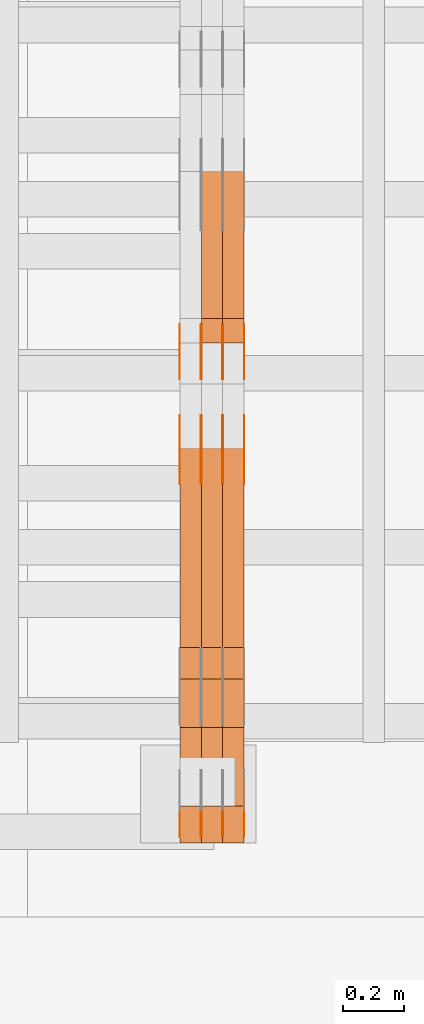
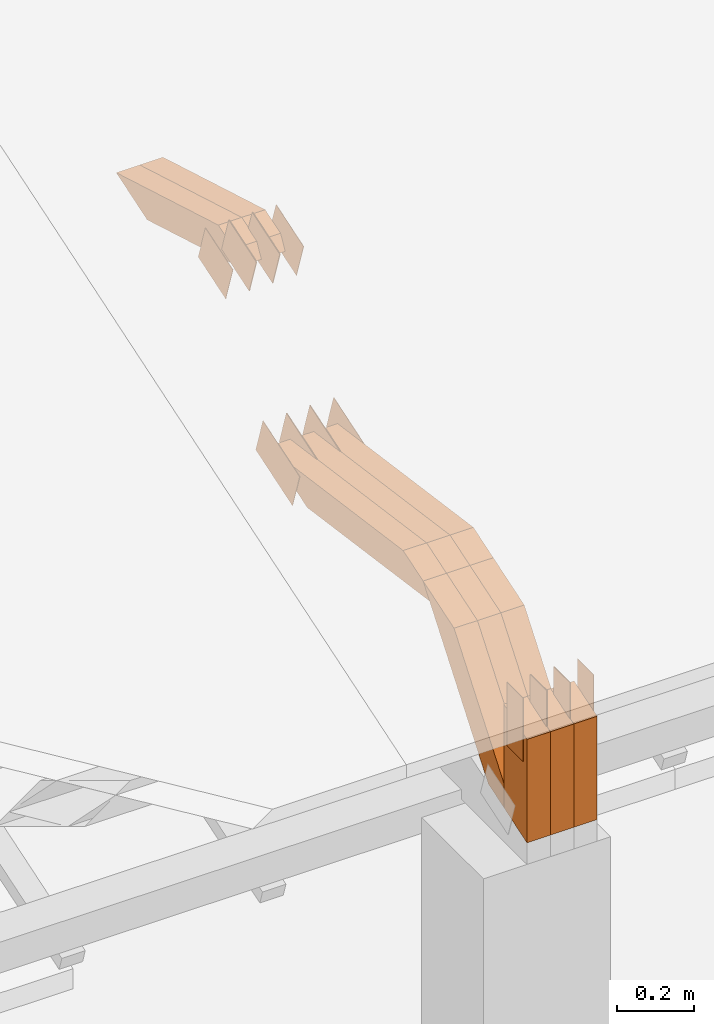
# One storey, part 35 of 385: 29 proxies.
"""IFC2X3 building model written with IfcOpenShell, lengths in millimetres."""

import ifcopenshell
import ifcopenshell.guid

model = None  # the IFC model being written
_history = None  # IfcOwnerHistory: only IFC2X3 demands one
_inside = {}  # id of a spatial element -> (the spatial element, [elements in it])
_under = {}  # id of a project, library or spatial element -> (it, [spatial elements below it])
_declared = {}  # id of a project -> (the project, [libraries it declares])
_typed = {}  # id of a type object -> (the type object, [elements of that type])
_made_of = {}  # id of a material, layer set ... -> (it, [elements and type objects made of it])


def new_model(schema):
    """Start an empty IFC model of exactly this schema.

    Asked for "IFC4X3", IfcOpenShell would pick the latest addendum, in which some entities
    have other attributes; the version numbers below select the first issue.
    IFC2X3 requires an IfcOwnerHistory on every rooted entity: one is made here for all.
    """
    global model, _history
    if schema == "IFC4X3":
        model = ifcopenshell.file(schema_version=(4, 3, 0, 0))
    else:
        model = ifcopenshell.file(schema=schema)
    _inside.clear()
    _under.clear()
    _declared.clear()
    _typed.clear()
    _made_of.clear()
    _history = None
    if model.schema == "IFC2X3":
        org = make("IfcOrganization", Name="unknown")
        user = make(
            "IfcPersonAndOrganization",
            ThePerson=make("IfcPerson", FamilyName="unknown"),
            TheOrganization=org,
        )
        app = make(
            "IfcApplication",
            ApplicationDeveloper=org,
            Version="unknown",
            ApplicationFullName="unknown",
            ApplicationIdentifier="unknown",
        )
        _history = make(
            "IfcOwnerHistory",
            OwningUser=user,
            OwningApplication=app,
            ChangeAction="ADDED",
            CreationDate=0,
        )
    return model


def make(cls, **values):
    """One entity of the class cls with the attributes given. An attribute that is None is left unset."""
    return model.create_entity(
        cls, **{name: value for name, value in values.items() if value is not None}
    )


def entity(cls, *values):
    """Any entity or typed value of the class cls, its attributes in the order of the schema. None: left unset."""
    e = model.create_entity(cls)
    for i, value in enumerate(values):
        if value is not None:
            e[i] = value
    return e


def rooted(cls, **values):
    """An entity with a GlobalId (a new one), such as an element, a storey or a relation."""
    return make(cls, GlobalId=ifcopenshell.guid.new(), OwnerHistory=_history, **values)


def si_unit(unit_type, name, prefix=None):
    """IfcSIUnit, for example si_unit("LENGTHUNIT", "METRE", prefix="MILLI")."""
    return make("IfcSIUnit", UnitType=unit_type, Prefix=prefix, Name=name)


def converted_unit(unit_type, name, factor, base, dimensions=None, offset=None):
    """IfcConversionBasedUnit, such as the inch: factor (a typed value) times the base unit."""
    return make(
        "IfcConversionBasedUnit"
        if offset is None
        else "IfcConversionBasedUnitWithOffset",
        ConversionOffset=offset,
        Dimensions=None
        if dimensions is None
        else entity("IfcDimensionalExponents", *dimensions),
        UnitType=unit_type,
        Name=name,
        ConversionFactor=make(
            "IfcMeasureWithUnit", ValueComponent=factor, UnitComponent=base
        ),
    )


def derived_unit(unit_type, elements):
    """IfcDerivedUnit: a product of units, each with its exponent."""
    return make(
        "IfcDerivedUnit",
        Elements=[
            make("IfcDerivedUnitElement", Unit=unit, Exponent=power)
            for unit, power in elements
        ],
        UnitType=unit_type,
    )


def assignment(units):
    """IfcUnitAssignment: the units of a project."""
    return None if units is None else make("IfcUnitAssignment", Units=units)


def point(xyz):
    """IfcCartesianPoint."""
    return None if xyz is None else make("IfcCartesianPoint", Coordinates=xyz)


def direction(xyz):
    """IfcDirection."""
    return None if xyz is None else make("IfcDirection", DirectionRatios=xyz)


def frame(location, z_axis=None, x_axis=None):
    """IfcAxis2Placement3D, a coordinate frame: its origin and axes. An axis left out is left unset."""
    return make(
        "IfcAxis2Placement3D",
        Location=point(location),
        Axis=direction(z_axis),
        RefDirection=direction(x_axis),
    )


def frame_2d(location, x_axis=None):
    """IfcAxis2Placement2D, a coordinate frame in the plane: its origin and x axis."""
    return make(
        "IfcAxis2Placement2D", Location=point(location), RefDirection=direction(x_axis)
    )


def origin():
    """The frame at (0, 0, 0) with its axes left unset."""
    return frame((0.0, 0.0, 0.0))


def place(relative_to, where):
    """IfcLocalPlacement: puts the frame where relative to a parent placement (None: the world)."""
    return make(
        "IfcLocalPlacement", PlacementRelTo=relative_to, RelativePlacement=where
    )


def context(
    kind, dimensions, precision=None, world=None, true_north=None, identifier=None
):
    """IfcGeometricRepresentationContext, for example the 3D "Model" context."""
    return make(
        "IfcGeometricRepresentationContext",
        ContextIdentifier=identifier,
        ContextType=kind,
        CoordinateSpaceDimension=dimensions,
        Precision=precision,
        WorldCoordinateSystem=world,
        TrueNorth=true_north,
    )


def subcontext(parent, identifier, kind, view, scale=None):
    """IfcGeometricRepresentationSubContext, for example "Body" below "Model"."""
    return make(
        "IfcGeometricRepresentationSubContext",
        ContextIdentifier=identifier,
        ContextType=kind,
        ParentContext=parent,
        TargetScale=scale,
        TargetView=view,
    )


def project(units=None, contexts=None):
    """IfcProject with its units and contexts."""
    return rooted(
        "IfcProject",
        Name="project",
        RepresentationContexts=contexts,
        UnitsInContext=assignment(units),
    )


def spatial(cls, under=None, at=None, **own):
    """A site, building, storey or space (cls), placed at a placement, below another one or the project."""
    s = rooted(cls, ObjectPlacement=at, **own)
    if under is not None:
        _under.setdefault(under.id(), (under, []))[1].append(s)
    return s


def polyline(points):
    """IfcPolyline through the points."""
    return make("IfcPolyline", Points=[point(p) for p in points])


def profile(cls, at=None, kind="AREA", **sizes):
    """A parametric profile (cls). Its sizes go by their IFC names, for example OverallWidth=200.0."""
    return make(cls, ProfileType=kind, Position=at, **sizes)


def rectangle(**sizes):
    """IfcRectangleProfileDef."""
    return profile("IfcRectangleProfileDef", **sizes)


def outline(outer, holes=None, kind="AREA"):
    """IfcArbitraryClosedProfileDef: a profile drawn as a closed curve; with holes, ...WithVoids."""
    if holes is None:
        return make("IfcArbitraryClosedProfileDef", ProfileType=kind, OuterCurve=outer)
    return make(
        "IfcArbitraryProfileDefWithVoids",
        ProfileType=kind,
        OuterCurve=outer,
        InnerCurves=holes,
    )


def extrude(swept, where, along, depth):
    """IfcExtrudedAreaSolid: the profile swept, set in the frame where, extruded along a direction by depth."""
    return make(
        "IfcExtrudedAreaSolid",
        SweptArea=swept,
        Position=where,
        ExtrudedDirection=direction(along),
        Depth=depth,
    )


def shape(context_of_items, identifier, shape_type, items):
    """IfcShapeRepresentation: the items that make up one representation, for example the "Body"."""
    return make(
        "IfcShapeRepresentation",
        ContextOfItems=context_of_items,
        RepresentationIdentifier=identifier,
        RepresentationType=shape_type,
        Items=items,
    )


def source(mapping_origin, context_of_items, identifier, shape_type, items):
    """IfcRepresentationMap: a shape defined once, which mapped items show again and again."""
    return make(
        "IfcRepresentationMap",
        MappingOrigin=mapping_origin,
        MappedRepresentation=shape(context_of_items, identifier, shape_type, items),
    )


def transform(
    local_origin,
    x_axis=None,
    y_axis=None,
    z_axis=None,
    scale=None,
    scale2=None,
    scale3=None,
    uniform=True,
):
    """IfcCartesianTransformationOperator3D, or its non-uniform kind. x_axis, y_axis, z_axis: its Axis1, 2, 3."""
    if uniform:
        return make(
            "IfcCartesianTransformationOperator3D",
            Axis1=direction(x_axis),
            Axis2=direction(y_axis),
            LocalOrigin=point(local_origin),
            Scale=scale,
            Axis3=direction(z_axis),
        )
    return make(
        "IfcCartesianTransformationOperator3DnonUniform",
        Axis1=direction(x_axis),
        Axis2=direction(y_axis),
        LocalOrigin=point(local_origin),
        Scale=scale,
        Axis3=direction(z_axis),
        Scale2=scale2,
        Scale3=scale3,
    )


def mapped(mapping_source, mapping_target):
    """IfcMappedItem: shows the shape of a source again, moved by a transform."""
    return make(
        "IfcMappedItem", MappingSource=mapping_source, MappingTarget=mapping_target
    )


def material(Name=None, Category=None):
    """IfcMaterial."""
    return make("IfcMaterial", Name=Name, Category=Category)


def made_of(thing, what):
    """Note that an element or type object is made of a material, layer set ...; save() writes the relation."""
    if what is not None:
        _made_of.setdefault(what.id(), (what, []))[1].append(thing)
    return thing


def type_object(cls, material=None, **own):
    """A type object (cls), such as IfcWallType, which elements share."""
    return made_of(rooted(cls, **own), material)


def type_shapes(of_type, sources):
    """Give a type object the sources (RepresentationMaps) that its elements show as mapped items."""
    of_type.RepresentationMaps = sources


def element(
    cls,
    number,
    at=None,
    inside=None,
    cuts=None,
    type_object=None,
    material=None,
    context=None,
    identifier="Body",
    shape_type=None,
    held_by="IfcProductDefinitionShape",
    body=None,
    shapes=None,
    **own,
):
    """One element of the class cls, such as IfcWall. Its Tag is "e" and its number.

    at: its placement. inside: the storey or other place that contains it. cuts: it is an
    opening in that element (IfcRelVoidsElement). A single representation is given by context,
    identifier, shape_type and body (its items); several are given by shapes. held_by: the class
    of the entity that holds the representations. save() writes the other relations.
    """
    e = rooted(cls, Tag="e%d" % number, ObjectPlacement=at, **own)
    if body is not None:
        shapes = [shape(context, identifier, shape_type, body)]
    if shapes is not None:
        e.Representation = make(held_by, Representations=shapes)
    if inside is not None:
        _inside.setdefault(inside.id(), (inside, []))[1].append(e)
    if cuts is not None:
        rooted(
            "IfcRelVoidsElement", RelatingBuildingElement=cuts, RelatedOpeningElement=e
        )
    if type_object is not None:
        _typed.setdefault(type_object.id(), (type_object, []))[1].append(e)
    return made_of(e, material)


def aggregate(whole, parts):
    """IfcRelAggregates: a whole, such as a stair, and the parts it consists of."""
    return rooted("IfcRelAggregates", RelatingObject=whole, RelatedObjects=parts)


def save(model, path):
    """Write the relations noted so far, then the file.

    IfcRelAggregates (storeys below a building ...), IfcRelContainedInSpatialStructure (elements
    in a storey), IfcRelDefinesByType, IfcRelAssociatesMaterial and IfcRelDeclares: one each for
    every whole, place, type object, material and project.
    """
    for whole, parts in _under.values():
        aggregate(whole, parts)
    for where, things in _inside.values():
        rooted(
            "IfcRelContainedInSpatialStructure",
            RelatedElements=things,
            RelatingStructure=where,
        )
    for kind, things in _typed.values():
        rooted("IfcRelDefinesByType", RelatedObjects=things, RelatingType=kind)
    for what, things in _made_of.values():
        rooted("IfcRelAssociatesMaterial", RelatedObjects=things, RelatingMaterial=what)
    for by, libraries in _declared.values():
        rooted("IfcRelDeclares", RelatingContext=by, RelatedDefinitions=libraries)
    model.write(path)


model = new_model("IFC2X3")

# Units and contexts
model_context = context("Model", 3, precision=0.01, world=origin(), true_north=direction((6.12303176911189e-17, 1.0)))
body_context = subcontext(model_context, "Body", "Model", "MODEL_VIEW")
ifc_project = project(units=[si_unit("LENGTHUNIT", "METRE", prefix="MILLI"), si_unit("AREAUNIT", "SQUARE_METRE"), si_unit("VOLUMEUNIT", "CUBIC_METRE"), converted_unit("PLANEANGLEUNIT", "DEGREE", entity("IfcRatioMeasure", 0.0174532925199433), si_unit("PLANEANGLEUNIT", "RADIAN"), dimensions=[0, 0, 0, 0, 0, 0, 0]), si_unit("MASSUNIT", "GRAM", prefix="KILO"), derived_unit("MASSDENSITYUNIT", [(si_unit("MASSUNIT", "GRAM", prefix="KILO"), 1), (si_unit("LENGTHUNIT", "METRE"), -3)]), si_unit("TIMEUNIT", "SECOND"), si_unit("FREQUENCYUNIT", "HERTZ"), si_unit("THERMODYNAMICTEMPERATUREUNIT", "DEGREE_CELSIUS"), derived_unit("THERMALTRANSMITTANCEUNIT", [(si_unit("MASSUNIT", "GRAM", prefix="KILO"), 1), (si_unit("THERMODYNAMICTEMPERATUREUNIT", "KELVIN"), -1), (si_unit("TIMEUNIT", "SECOND"), -3)]), derived_unit("VOLUMETRICFLOWRATEUNIT", [(si_unit("LENGTHUNIT", "METRE"), 3), (si_unit("TIMEUNIT", "SECOND"), -1)]), si_unit("ELECTRICCURRENTUNIT", "AMPERE"), si_unit("ELECTRICVOLTAGEUNIT", "VOLT"), si_unit("POWERUNIT", "WATT"), si_unit("FORCEUNIT", "NEWTON", prefix="KILO"), si_unit("ILLUMINANCEUNIT", "LUX"), si_unit("LUMINOUSFLUXUNIT", "LUMEN"), si_unit("LUMINOUSINTENSITYUNIT", "CANDELA"), derived_unit("USERDEFINED", [(si_unit("MASSUNIT", "GRAM", prefix="KILO"), -1), (si_unit("LENGTHUNIT", "METRE"), -2), (si_unit("TIMEUNIT", "SECOND"), 3), (si_unit("LUMINOUSFLUXUNIT", "LUMEN"), 1)]), derived_unit("LINEARVELOCITYUNIT", [(si_unit("LENGTHUNIT", "METRE"), 1), (si_unit("TIMEUNIT", "SECOND"), -1)]), si_unit("PRESSUREUNIT", "PASCAL"), derived_unit("USERDEFINED", [(si_unit("LENGTHUNIT", "METRE"), -2), (si_unit("MASSUNIT", "GRAM", prefix="KILO"), 1), (si_unit("TIMEUNIT", "SECOND"), -2)])], contexts=[model_context])

# Site, building, storey
site_placement = place(None, origin())
site = spatial("IfcSite", under=ifc_project, at=site_placement, CompositionType="ELEMENT")
building_placement = place(site_placement, origin())
building = spatial("IfcBuilding", under=site, at=building_placement, CompositionType="ELEMENT")
storey_placement = place(building_placement, origin())
storey = spatial("IfcBuildingStorey", under=building, at=storey_placement, Name="Default", CompositionType="ELEMENT", Elevation=0.0)

# Proxies
ifc_material_1 = material(Name="IfcSurfaceStyle #64230")
building_element_proxy_type_1 = type_object("IfcBuildingElementProxyType", PredefinedType="NOTDEFINED", material=ifc_material_1)
shared_shape_1 = source(origin(), body_context, "Body", "SweptSolid", [
    extrude(outline(polyline([(-99.9998204243802, -60.000067376167), (99.9998338462265, -60.000067376167), (99.9998204243802, 60.000067376167), (-99.9998338462265, 60.000067376167), (-99.9998204243802, -60.000067376167)])), frame((100.000602015329, 60.0001864986889, 0.0), z_axis=(0.0, 0.0, 1.0), x_axis=(-1.0, 0.0, 0.0)), (0.0, 0.0, 1.0), 1.3),
])
type_shapes(building_element_proxy_type_1, [shared_shape_1])
proxy_1_placement = place(building_placement, frame((3386.29999999999, 4114.85465165112, 513.097031388771), z_axis=(-1.0, 0.0, 0.0), x_axis=(0.0, 0.951056516295124, 0.309016994375039)))
element("IfcBuildingElementProxy", 1, at=proxy_1_placement, inside=storey, type_object=building_element_proxy_type_1, material=ifc_material_1, context=body_context, shape_type="MappedRepresentation", body=[
    mapped(shared_shape_1, transform((0.0, 0.0, 0.0), scale=1.0)),
])
ifc_material_2 = material(Name="IfcSurfaceStyle #64173")
building_element_proxy_type_2 = type_object("IfcBuildingElementProxyType", PredefinedType="NOTDEFINED", material=ifc_material_2)
shared_shape_2 = source(origin(), body_context, "Body", "SweptSolid", [
    extrude(outline(polyline([(-99.9998204243802, -60.000067376167), (99.9998338462265, -60.000067376167), (99.9998204243802, 60.000067376167), (-99.9998338462265, 60.000067376167), (-99.9998204243802, -60.000067376167)])), frame((100.000602015329, 60.0001864986889, 0.0), z_axis=(0.0, 0.0, 1.0), x_axis=(-1.0, 0.0, 0.0)), (0.0, 0.0, 1.0), 1.3),
])
type_shapes(building_element_proxy_type_2, [shared_shape_2])
proxy_2_placement = place(building_placement, frame((3315.0, 4114.85465165112, 513.097031388771), z_axis=(-1.0, 0.0, 0.0), x_axis=(0.0, 0.951056516295124, 0.309016994375039)))
element("IfcBuildingElementProxy", 2, at=proxy_2_placement, inside=storey, type_object=building_element_proxy_type_2, material=ifc_material_2, context=body_context, shape_type="MappedRepresentation", body=[
    mapped(shared_shape_2, transform((0.0, 0.0, 0.0), scale=1.0)),
])
ifc_material_3 = material(Name="IfcSurfaceStyle #64116")
building_element_proxy_type_3 = type_object("IfcBuildingElementProxyType", PredefinedType="NOTDEFINED", material=ifc_material_3)
shared_shape_3 = source(origin(), body_context, "Body", "SweptSolid", [
    extrude(outline(polyline([(-99.9998204243802, -60.000067376167), (99.9998338462265, -60.000067376167), (99.9998204243802, 60.000067376167), (-99.9998338462265, 60.000067376167), (-99.9998204243802, -60.000067376167)])), frame((100.000602015329, 60.0001864986889, 0.0), z_axis=(0.0, 0.0, 1.0), x_axis=(-1.0, 0.0, 0.0)), (0.0, 0.0, 1.0), 1.3),
])
type_shapes(building_element_proxy_type_3, [shared_shape_3])
proxy_3_placement = place(building_placement, frame((3316.29999999999, 4114.85465165112, 513.097031388771), z_axis=(-1.0, 0.0, 0.0), x_axis=(0.0, 0.951056516295124, 0.309016994375039)))
element("IfcBuildingElementProxy", 3, at=proxy_3_placement, inside=storey, type_object=building_element_proxy_type_3, material=ifc_material_3, context=body_context, shape_type="MappedRepresentation", body=[
    mapped(shared_shape_3, transform((0.0, 0.0, 0.0), scale=1.0)),
])
ifc_material_4 = material(Name="IfcSurfaceStyle #64059")
building_element_proxy_type_4 = type_object("IfcBuildingElementProxyType", PredefinedType="NOTDEFINED", material=ifc_material_4)
shared_shape_4 = source(origin(), body_context, "Body", "SweptSolid", [
    extrude(outline(polyline([(-99.9998204243802, -60.000067376167), (99.9998338462265, -60.000067376167), (99.9998204243802, 60.000067376167), (-99.9998338462265, 60.000067376167), (-99.9998204243802, -60.000067376167)])), frame((100.000602015329, 60.0001864986889, 0.0), z_axis=(0.0, 0.0, 1.0), x_axis=(-1.0, 0.0, 0.0)), (0.0, 0.0, 1.0), 1.29999999999998),
])
type_shapes(building_element_proxy_type_4, [shared_shape_4])
proxy_4_placement = place(building_placement, frame((3245.0, 4114.85465165112, 513.097031388771), z_axis=(-1.0, 0.0, 0.0), x_axis=(0.0, 0.951056516295124, 0.309016994375039)))
element("IfcBuildingElementProxy", 4, at=proxy_4_placement, inside=storey, type_object=building_element_proxy_type_4, material=ifc_material_4, context=body_context, shape_type="MappedRepresentation", body=[
    mapped(shared_shape_4, transform((0.0, 0.0, 0.0), scale=1.0)),
])
ifc_material_5 = material(Name="IfcSurfaceStyle #64002")
building_element_proxy_type_5 = type_object("IfcBuildingElementProxyType", PredefinedType="NOTDEFINED", material=ifc_material_5)
shared_shape_5 = source(origin(), body_context, "Body", "SweptSolid", [
    extrude(outline(polyline([(-99.9998204243802, -60.000067376167), (99.9998338462265, -60.000067376167), (99.9998204243802, 60.000067376167), (-99.9998338462265, 60.000067376167), (-99.9998204243802, -60.000067376167)])), frame((100.000602015329, 60.0001864986889, 0.0), z_axis=(0.0, 0.0, 1.0), x_axis=(-1.0, 0.0, 0.0)), (0.0, 0.0, 1.0), 1.29999999999998),
])
type_shapes(building_element_proxy_type_5, [shared_shape_5])
proxy_5_placement = place(building_placement, frame((3246.29999999999, 4114.85465165112, 513.097031388771), z_axis=(-1.0, 0.0, 0.0), x_axis=(0.0, 0.951056516295124, 0.309016994375039)))
element("IfcBuildingElementProxy", 5, at=proxy_5_placement, inside=storey, type_object=building_element_proxy_type_5, material=ifc_material_5, context=body_context, shape_type="MappedRepresentation", body=[
    mapped(shared_shape_5, transform((0.0, 0.0, 0.0), scale=1.0)),
])
ifc_material_6 = material(Name="IfcSurfaceStyle #63945")
building_element_proxy_type_6 = type_object("IfcBuildingElementProxyType", PredefinedType="NOTDEFINED", material=ifc_material_6)
shared_shape_6 = source(origin(), body_context, "Body", "SweptSolid", [
    extrude(outline(polyline([(-99.9998204243802, -60.000067376167), (99.9998338462265, -60.000067376167), (99.9998204243802, 60.000067376167), (-99.9998338462265, 60.000067376167), (-99.9998204243802, -60.000067376167)])), frame((100.000602015329, 60.0001864986889, 0.0), z_axis=(0.0, 0.0, 1.0), x_axis=(-1.0, 0.0, 0.0)), (0.0, 0.0, 1.0), 1.29999999999999),
])
type_shapes(building_element_proxy_type_6, [shared_shape_6])
proxy_6_placement = place(building_placement, frame((3175.0, 4114.85465165112, 513.097031388771), z_axis=(-1.0, 0.0, 0.0), x_axis=(0.0, 0.951056516295124, 0.309016994375039)))
element("IfcBuildingElementProxy", 6, at=proxy_6_placement, inside=storey, type_object=building_element_proxy_type_6, material=ifc_material_6, context=body_context, shape_type="MappedRepresentation", body=[
    mapped(shared_shape_6, transform((0.0, 0.0, 0.0), scale=1.0)),
])
ifc_material_7 = material(Name="IfcSurfaceStyle #57048")
building_element_proxy_type_7 = type_object("IfcBuildingElementProxyType", PredefinedType="NOTDEFINED", material=ifc_material_7)
shared_shape_7 = source(origin(), body_context, "Body", "SweptSolid", [
    extrude(outline(polyline([(-74.999865998172, -60.0000306612919), (74.999869989555, -60.0000306612919), (74.999865998172, 60.0000306612919), (-74.999869989555, 60.0000306612919), (-74.999865998172, -60.0000306612919)])), frame((75.0006726017528, 60.0001996460842, 0.0), z_axis=(0.0, 0.0, 1.0), x_axis=(-1.0, 0.0, 0.0)), (0.0, 0.0, 1.0), 1.3),
])
type_shapes(building_element_proxy_type_7, [shared_shape_7])
proxy_7_placement = place(building_placement, frame((3386.29999999999, 4460.38978242656, 957.314497110567), z_axis=(-1.0, 0.0, 0.0), x_axis=(0.0, 0.951056516295154, 0.309016994374948)))
element("IfcBuildingElementProxy", 7, at=proxy_7_placement, inside=storey, type_object=building_element_proxy_type_7, material=ifc_material_7, context=body_context, shape_type="MappedRepresentation", body=[
    mapped(shared_shape_7, transform((0.0, 0.0, 0.0), scale=1.0)),
])
ifc_material_8 = material(Name="IfcSurfaceStyle #56991")
building_element_proxy_type_8 = type_object("IfcBuildingElementProxyType", PredefinedType="NOTDEFINED", material=ifc_material_8)
shared_shape_8 = source(origin(), body_context, "Body", "SweptSolid", [
    extrude(outline(polyline([(-74.999865998172, -60.0000306612919), (74.999869989555, -60.0000306612919), (74.999865998172, 60.0000306612919), (-74.999869989555, 60.0000306612919), (-74.999865998172, -60.0000306612919)])), frame((75.0006726017528, 60.0001996460842, 0.0), z_axis=(0.0, 0.0, 1.0), x_axis=(-1.0, 0.0, 0.0)), (0.0, 0.0, 1.0), 1.3),
])
type_shapes(building_element_proxy_type_8, [shared_shape_8])
proxy_8_placement = place(building_placement, frame((3315.0, 4460.38978242656, 957.314497110567), z_axis=(-1.0, 0.0, 0.0), x_axis=(0.0, 0.951056516295154, 0.309016994374948)))
element("IfcBuildingElementProxy", 8, at=proxy_8_placement, inside=storey, type_object=building_element_proxy_type_8, material=ifc_material_8, context=body_context, shape_type="MappedRepresentation", body=[
    mapped(shared_shape_8, transform((0.0, 0.0, 0.0), scale=1.0)),
])
ifc_material_9 = material(Name="IfcSurfaceStyle #56934")
building_element_proxy_type_9 = type_object("IfcBuildingElementProxyType", PredefinedType="NOTDEFINED", material=ifc_material_9)
shared_shape_9 = source(origin(), body_context, "Body", "SweptSolid", [
    extrude(outline(polyline([(-74.999865998172, -60.0000306612919), (74.999869989555, -60.0000306612919), (74.999865998172, 60.0000306612919), (-74.999869989555, 60.0000306612919), (-74.999865998172, -60.0000306612919)])), frame((75.0006726017528, 60.0001996460842, 0.0), z_axis=(0.0, 0.0, 1.0), x_axis=(-1.0, 0.0, 0.0)), (0.0, 0.0, 1.0), 1.3),
])
type_shapes(building_element_proxy_type_9, [shared_shape_9])
proxy_9_placement = place(building_placement, frame((3316.29999999999, 4460.38978242656, 957.314497110567), z_axis=(-1.0, 0.0, 0.0), x_axis=(0.0, 0.951056516295154, 0.309016994374948)))
element("IfcBuildingElementProxy", 9, at=proxy_9_placement, inside=storey, type_object=building_element_proxy_type_9, material=ifc_material_9, context=body_context, shape_type="MappedRepresentation", body=[
    mapped(shared_shape_9, transform((0.0, 0.0, 0.0), scale=1.0)),
])
ifc_material_10 = material(Name="IfcSurfaceStyle #56877")
building_element_proxy_type_10 = type_object("IfcBuildingElementProxyType", PredefinedType="NOTDEFINED", material=ifc_material_10)
shared_shape_10 = source(origin(), body_context, "Body", "SweptSolid", [
    extrude(outline(polyline([(-74.999865998172, -60.0000306612919), (74.999869989555, -60.0000306612919), (74.999865998172, 60.0000306612919), (-74.999869989555, 60.0000306612919), (-74.999865998172, -60.0000306612919)])), frame((75.0006726017528, 60.0001996460842, 0.0), z_axis=(0.0, 0.0, 1.0), x_axis=(-1.0, 0.0, 0.0)), (0.0, 0.0, 1.0), 1.29999999999999),
])
type_shapes(building_element_proxy_type_10, [shared_shape_10])
proxy_10_placement = place(building_placement, frame((3245.0, 4460.38978242656, 957.314497110567), z_axis=(-1.0, 0.0, 0.0), x_axis=(0.0, 0.951056516295154, 0.309016994374948)))
element("IfcBuildingElementProxy", 10, at=proxy_10_placement, inside=storey, type_object=building_element_proxy_type_10, material=ifc_material_10, context=body_context, shape_type="MappedRepresentation", body=[
    mapped(shared_shape_10, transform((0.0, 0.0, 0.0), scale=1.0)),
])
ifc_material_11 = material(Name="IfcSurfaceStyle #56820")
building_element_proxy_type_11 = type_object("IfcBuildingElementProxyType", PredefinedType="NOTDEFINED", material=ifc_material_11)
shared_shape_11 = source(origin(), body_context, "Body", "SweptSolid", [
    extrude(outline(polyline([(-74.999865998172, -60.0000306612919), (74.999869989555, -60.0000306612919), (74.999865998172, 60.0000306612919), (-74.999869989555, 60.0000306612919), (-74.999865998172, -60.0000306612919)])), frame((75.0006726017528, 60.0001996460842, 0.0), z_axis=(0.0, 0.0, 1.0), x_axis=(-1.0, 0.0, 0.0)), (0.0, 0.0, 1.0), 1.29999999999999),
])
type_shapes(building_element_proxy_type_11, [shared_shape_11])
proxy_11_placement = place(building_placement, frame((3246.29999999999, 4460.38978242656, 957.314497110567), z_axis=(-1.0, 0.0, 0.0), x_axis=(0.0, 0.951056516295154, 0.309016994374948)))
element("IfcBuildingElementProxy", 11, at=proxy_11_placement, inside=storey, type_object=building_element_proxy_type_11, material=ifc_material_11, context=body_context, shape_type="MappedRepresentation", body=[
    mapped(shared_shape_11, transform((0.0, 0.0, 0.0), scale=1.0)),
])
ifc_material_12 = material(Name="IfcSurfaceStyle #56763")
building_element_proxy_type_12 = type_object("IfcBuildingElementProxyType", PredefinedType="NOTDEFINED", material=ifc_material_12)
shared_shape_12 = source(origin(), body_context, "Body", "SweptSolid", [
    extrude(outline(polyline([(-74.999865998172, -60.0000306612919), (74.999869989555, -60.0000306612919), (74.999865998172, 60.0000306612919), (-74.999869989555, 60.0000306612919), (-74.999865998172, -60.0000306612919)])), frame((75.0006726017528, 60.0001996460842, 0.0), z_axis=(0.0, 0.0, 1.0), x_axis=(-1.0, 0.0, 0.0)), (0.0, 0.0, 1.0), 1.29999999999999),
])
type_shapes(building_element_proxy_type_12, [shared_shape_12])
proxy_12_placement = place(building_placement, frame((3175.0, 4460.38978242656, 957.314497110567), z_axis=(-1.0, 0.0, 0.0), x_axis=(0.0, 0.951056516295154, 0.309016994374948)))
element("IfcBuildingElementProxy", 12, at=proxy_12_placement, inside=storey, type_object=building_element_proxy_type_12, material=ifc_material_12, context=body_context, shape_type="MappedRepresentation", body=[
    mapped(shared_shape_12, transform((0.0, 0.0, 0.0), scale=1.0)),
])
ifc_material_13 = material(Name="IfcSurfaceStyle #54996")
building_element_proxy_type_13 = type_object("IfcBuildingElementProxyType", PredefinedType="NOTDEFINED", material=ifc_material_13)
shared_shape_13 = source(origin(), body_context, "Body", "SweptSolid", [
    extrude(rectangle(XDim=199.999969482422, YDim=84.0, at=frame_2d((1.4210854715202e-14, 0.0), x_axis=(1.0, 0.0))), frame((100.000010815955, 42.0, 0.0), z_axis=(0.0, 0.0, 1.0), x_axis=(-1.0, 0.0, 0.0)), (0.0, 0.0, 1.0), 1.3),
])
type_shapes(building_element_proxy_type_13, [shared_shape_13])
proxy_13_placement = place(building_placement, frame((3386.29999999999, 3042.0, 514.460048047401), z_axis=(-1.0, 0.0, 0.0), x_axis=(0.0, 0.0, -1.0)))
element("IfcBuildingElementProxy", 13, at=proxy_13_placement, inside=storey, type_object=building_element_proxy_type_13, material=ifc_material_13, context=body_context, shape_type="MappedRepresentation", body=[
    mapped(shared_shape_13, transform((0.0, 0.0, 0.0), scale=1.0)),
])
ifc_material_14 = material(Name="IfcSurfaceStyle #54939")
building_element_proxy_type_14 = type_object("IfcBuildingElementProxyType", PredefinedType="NOTDEFINED", material=ifc_material_14)
shared_shape_14 = source(origin(), body_context, "Body", "SweptSolid", [
    extrude(rectangle(XDim=199.999969482422, YDim=84.0, at=frame_2d((1.4210854715202e-14, 0.0), x_axis=(1.0, 0.0))), frame((100.000010815955, 42.0, 0.0), z_axis=(0.0, 0.0, 1.0), x_axis=(-1.0, 0.0, 0.0)), (0.0, 0.0, 1.0), 1.3),
])
type_shapes(building_element_proxy_type_14, [shared_shape_14])
proxy_14_placement = place(building_placement, frame((3315.0, 3042.0, 514.460048047401), z_axis=(-1.0, 0.0, 0.0), x_axis=(0.0, 0.0, -1.0)))
element("IfcBuildingElementProxy", 14, at=proxy_14_placement, inside=storey, type_object=building_element_proxy_type_14, material=ifc_material_14, context=body_context, shape_type="MappedRepresentation", body=[
    mapped(shared_shape_14, transform((0.0, 0.0, 0.0), scale=1.0)),
])
ifc_material_15 = material(Name="IfcSurfaceStyle #54882")
building_element_proxy_type_15 = type_object("IfcBuildingElementProxyType", PredefinedType="NOTDEFINED", material=ifc_material_15)
shared_shape_15 = source(origin(), body_context, "Body", "SweptSolid", [
    extrude(rectangle(XDim=199.999969482422, YDim=84.0, at=frame_2d((1.4210854715202e-14, 0.0), x_axis=(1.0, 0.0))), frame((100.000010815955, 42.0, 0.0), z_axis=(0.0, 0.0, 1.0), x_axis=(-1.0, 0.0, 0.0)), (0.0, 0.0, 1.0), 1.3),
])
type_shapes(building_element_proxy_type_15, [shared_shape_15])
proxy_15_placement = place(building_placement, frame((3316.29999999999, 3042.0, 514.460048047401), z_axis=(-1.0, 0.0, 0.0), x_axis=(0.0, 0.0, -1.0)))
element("IfcBuildingElementProxy", 15, at=proxy_15_placement, inside=storey, type_object=building_element_proxy_type_15, material=ifc_material_15, context=body_context, shape_type="MappedRepresentation", body=[
    mapped(shared_shape_15, transform((0.0, 0.0, 0.0), scale=1.0)),
])
ifc_material_16 = material(Name="IfcSurfaceStyle #54825")
building_element_proxy_type_16 = type_object("IfcBuildingElementProxyType", PredefinedType="NOTDEFINED", material=ifc_material_16)
shared_shape_16 = source(origin(), body_context, "Body", "SweptSolid", [
    extrude(rectangle(XDim=199.999969482422, YDim=84.0, at=frame_2d((1.4210854715202e-14, 0.0), x_axis=(1.0, 0.0))), frame((100.000010815955, 42.0, 0.0), z_axis=(0.0, 0.0, 1.0), x_axis=(-1.0, 0.0, 0.0)), (0.0, 0.0, 1.0), 1.29999999999998),
])
type_shapes(building_element_proxy_type_16, [shared_shape_16])
proxy_16_placement = place(building_placement, frame((3245.0, 3042.0, 514.460048047401), z_axis=(-1.0, 0.0, 0.0), x_axis=(0.0, 0.0, -1.0)))
element("IfcBuildingElementProxy", 16, at=proxy_16_placement, inside=storey, type_object=building_element_proxy_type_16, material=ifc_material_16, context=body_context, shape_type="MappedRepresentation", body=[
    mapped(shared_shape_16, transform((0.0, 0.0, 0.0), scale=1.0)),
])
ifc_material_17 = material(Name="IfcSurfaceStyle #54768")
building_element_proxy_type_17 = type_object("IfcBuildingElementProxyType", PredefinedType="NOTDEFINED", material=ifc_material_17)
shared_shape_17 = source(origin(), body_context, "Body", "SweptSolid", [
    extrude(rectangle(XDim=199.999969482422, YDim=84.0, at=frame_2d((1.4210854715202e-14, 0.0), x_axis=(1.0, 0.0))), frame((100.000010815955, 42.0, 0.0), z_axis=(0.0, 0.0, 1.0), x_axis=(-1.0, 0.0, 0.0)), (0.0, 0.0, 1.0), 1.29999999999998),
])
type_shapes(building_element_proxy_type_17, [shared_shape_17])
proxy_17_placement = place(building_placement, frame((3246.29999999999, 3042.0, 514.460048047401), z_axis=(-1.0, 0.0, 0.0), x_axis=(0.0, 0.0, -1.0)))
element("IfcBuildingElementProxy", 17, at=proxy_17_placement, inside=storey, type_object=building_element_proxy_type_17, material=ifc_material_17, context=body_context, shape_type="MappedRepresentation", body=[
    mapped(shared_shape_17, transform((0.0, 0.0, 0.0), scale=1.0)),
])
ifc_material_18 = material(Name="IfcSurfaceStyle #54711")
building_element_proxy_type_18 = type_object("IfcBuildingElementProxyType", PredefinedType="NOTDEFINED", material=ifc_material_18)
shared_shape_18 = source(origin(), body_context, "Body", "SweptSolid", [
    extrude(rectangle(XDim=199.999969482422, YDim=84.0, at=frame_2d((1.4210854715202e-14, 0.0), x_axis=(1.0, 0.0))), frame((100.000010815955, 42.0, 0.0), z_axis=(0.0, 0.0, 1.0), x_axis=(-1.0, 0.0, 0.0)), (0.0, 0.0, 1.0), 1.29999999999999),
])
type_shapes(building_element_proxy_type_18, [shared_shape_18])
proxy_18_placement = place(building_placement, frame((3175.0, 3042.0, 514.460048047401), z_axis=(-1.0, 0.0, 0.0), x_axis=(0.0, 0.0, -1.0)))
element("IfcBuildingElementProxy", 18, at=proxy_18_placement, inside=storey, type_object=building_element_proxy_type_18, material=ifc_material_18, context=body_context, shape_type="MappedRepresentation", body=[
    mapped(shared_shape_18, transform((0.0, 0.0, 0.0), scale=1.0)),
])
ifc_material_19 = material(Name="IfcSurfaceStyle #44520")
building_element_proxy_type_19 = type_object("IfcBuildingElementProxyType", Name="T1-W12 44518", PredefinedType="NOTDEFINED", material=ifc_material_19)
shared_shape_19 = source(origin(), body_context, "Body", "SweptSolid", [
    extrude(outline(polyline([(-249.405625983165, -47.5001691155616), (243.345753908996, -47.5001691155616), (232.115534842595, 2.39993474701938e-05), (162.527010966644, 47.5001571158879), (-388.58267373507, 47.5001571158879), (-249.405625983165, -47.5001691155616)])), frame((243.345867653852, 47.5001571158879, 0.0), z_axis=(0.0, 0.0, 1.0), x_axis=(-1.0, 0.0, 0.0)), (0.0, 0.0, 1.0), 70.0),
])
type_shapes(building_element_proxy_type_19, [shared_shape_19])
proxy_19_placement = place(building_placement, frame((3385.0, 4581.32698473631, 976.172276753357), z_axis=(-1.0, 0.0, 0.0), x_axis=(0.0, 0.959722067881787, -0.280951156645966)))
element("IfcBuildingElementProxy", 19, at=proxy_19_placement, inside=storey, type_object=building_element_proxy_type_19, material=ifc_material_19, Name="T1-W12", context=body_context, shape_type="MappedRepresentation", body=[
    mapped(shared_shape_19, transform((0.0, 0.0, 0.0), scale=1.0)),
])
ifc_material_20 = material(Name="IfcSurfaceStyle #44454")
building_element_proxy_type_20 = type_object("IfcBuildingElementProxyType", Name="T1-W12 44452", PredefinedType="NOTDEFINED", material=ifc_material_20)
shared_shape_20 = source(origin(), body_context, "Body", "SweptSolid", [
    extrude(outline(polyline([(-249.405625983165, -47.5001691155616), (243.345753908996, -47.5001691155616), (232.115534842595, 2.39993474701938e-05), (162.527010966644, 47.5001571158879), (-388.58267373507, 47.5001571158879), (-249.405625983165, -47.5001691155616)])), frame((243.345867653852, 47.5001571158879, 0.0), z_axis=(0.0, 0.0, 1.0), x_axis=(-1.0, 0.0, 0.0)), (0.0, 0.0, 1.0), 70.0),
])
type_shapes(building_element_proxy_type_20, [shared_shape_20])
proxy_20_placement = place(building_placement, frame((3315.0, 4581.32698473631, 976.172276753357), z_axis=(-1.0, 0.0, 0.0), x_axis=(0.0, 0.959722067881787, -0.280951156645966)))
element("IfcBuildingElementProxy", 20, at=proxy_20_placement, inside=storey, type_object=building_element_proxy_type_20, material=ifc_material_20, Name="T1-W12", context=body_context, shape_type="MappedRepresentation", body=[
    mapped(shared_shape_20, transform((0.0, 0.0, 0.0), scale=1.0)),
])
ifc_material_21 = material(Name="IfcSurfaceStyle #43728")
building_element_proxy_type_21 = type_object("IfcBuildingElementProxyType", Name="T1-W3 43726", PredefinedType="NOTDEFINED", material=ifc_material_21)
shared_shape_21 = source(origin(), body_context, "Body", "SweptSolid", [
    extrude(outline(polyline([(-314.232579911788, -47.5000200125938), (325.164873061766, -47.5000200125938), (297.999869081008, 6.48085173424295e-05), (200.434027234171, 47.4999876083351), (-509.366189465157, 47.4999876083352), (-314.232579911788, -47.5000200125938)])), frame((325.164873061766, 47.5001564752191, 0.0), z_axis=(0.0, 0.0, 1.0), x_axis=(-1.0, 0.0, 0.0)), (0.0, 0.0, 1.0), 70.0),
])
type_shapes(building_element_proxy_type_21, [shared_shape_21])
proxy_21_placement = place(building_placement, frame((3385.0, 3457.43747924875, 620.49890325051), z_axis=(-1.0, 0.0, 0.0), x_axis=(0.0, 0.990367219823621, -0.138465771578512)))
element("IfcBuildingElementProxy", 21, at=proxy_21_placement, inside=storey, type_object=building_element_proxy_type_21, material=ifc_material_21, Name="T1-W3", context=body_context, shape_type="MappedRepresentation", body=[
    mapped(shared_shape_21, transform((0.0, 0.0, 0.0), scale=1.0)),
])
ifc_material_22 = material(Name="IfcSurfaceStyle #43662")
building_element_proxy_type_22 = type_object("IfcBuildingElementProxyType", Name="T1-W3 43660", PredefinedType="NOTDEFINED", material=ifc_material_22)
shared_shape_22 = source(origin(), body_context, "Body", "SweptSolid", [
    extrude(outline(polyline([(-314.232579911788, -47.5000200125938), (325.164873061766, -47.5000200125938), (297.999869081008, 6.48085173424295e-05), (200.434027234171, 47.4999876083351), (-509.366189465157, 47.4999876083352), (-314.232579911788, -47.5000200125938)])), frame((325.164873061766, 47.5001564752191, 0.0), z_axis=(0.0, 0.0, 1.0), x_axis=(-1.0, 0.0, 0.0)), (0.0, 0.0, 1.0), 70.0),
])
type_shapes(building_element_proxy_type_22, [shared_shape_22])
proxy_22_placement = place(building_placement, frame((3315.0, 3457.43747924875, 620.49890325051), z_axis=(-1.0, 0.0, 0.0), x_axis=(0.0, 0.990367219823621, -0.138465771578512)))
element("IfcBuildingElementProxy", 22, at=proxy_22_placement, inside=storey, type_object=building_element_proxy_type_22, material=ifc_material_22, Name="T1-W3", context=body_context, shape_type="MappedRepresentation", body=[
    mapped(shared_shape_22, transform((0.0, 0.0, 0.0), scale=1.0)),
])
ifc_material_23 = material(Name="IfcSurfaceStyle #43596")
building_element_proxy_type_23 = type_object("IfcBuildingElementProxyType", Name="T1-W3 43594", PredefinedType="NOTDEFINED", material=ifc_material_23)
shared_shape_23 = source(origin(), body_context, "Body", "SweptSolid", [
    extrude(outline(polyline([(-314.232579911788, -47.5000200125938), (325.164873061766, -47.5000200125938), (297.999869081008, 6.48085173424295e-05), (200.434027234171, 47.4999876083351), (-509.366189465157, 47.4999876083352), (-314.232579911788, -47.5000200125938)])), frame((325.164873061766, 47.5001564752191, 0.0), z_axis=(0.0, 0.0, 1.0), x_axis=(-1.0, 0.0, 0.0)), (0.0, 0.0, 1.0), 70.0),
])
type_shapes(building_element_proxy_type_23, [shared_shape_23])
proxy_23_placement = place(building_placement, frame((3245.0, 3457.43747924875, 620.49890325051), z_axis=(-1.0, 0.0, 0.0), x_axis=(0.0, 0.990367219823621, -0.138465771578512)))
element("IfcBuildingElementProxy", 23, at=proxy_23_placement, inside=storey, type_object=building_element_proxy_type_23, material=ifc_material_23, Name="T1-W3", context=body_context, shape_type="MappedRepresentation", body=[
    mapped(shared_shape_23, transform((0.0, 0.0, 0.0), scale=1.0)),
])
ifc_material_24 = material(Name="IfcSurfaceStyle #43332")
building_element_proxy_type_24 = type_object("IfcBuildingElementProxyType", Name="T1-W14 43330", PredefinedType="NOTDEFINED", material=ifc_material_24)
shared_shape_24 = source(origin(), body_context, "Body", "SweptSolid", [
    extrude(outline(polyline([(-374.484689776928, -47.499919737532), (177.199556189275, -47.499919737532), (246.893257937645, -5.36774925340877e-05), (185.487930694801, 47.4999465762783), (-235.096055044793, 47.4999465762784), (-374.484689776928, -47.499919737532)])), frame((246.893257937645, 47.5000959779252, 0.0), z_axis=(0.0, 0.0, 1.0), x_axis=(-1.0, 0.0, 0.0)), (0.0, 0.0, 1.0), 70.0),
])
type_shapes(building_element_proxy_type_24, [shared_shape_24])
proxy_24_placement = place(building_placement, frame((3385.0, 3022.42877773024, 136.329406512195), z_axis=(-1.0, 0.0, 0.0), x_axis=(0.0, 0.611854146609475, 0.790970608352037)))
element("IfcBuildingElementProxy", 24, at=proxy_24_placement, inside=storey, type_object=building_element_proxy_type_24, material=ifc_material_24, Name="T1-W14", context=body_context, shape_type="MappedRepresentation", body=[
    mapped(shared_shape_24, transform((0.0, 0.0, 0.0), scale=1.0)),
])
ifc_material_25 = material(Name="IfcSurfaceStyle #43266")
building_element_proxy_type_25 = type_object("IfcBuildingElementProxyType", Name="T1-W14 43264", PredefinedType="NOTDEFINED", material=ifc_material_25)
shared_shape_25 = source(origin(), body_context, "Body", "SweptSolid", [
    extrude(outline(polyline([(-374.484689776928, -47.499919737532), (177.199556189275, -47.499919737532), (246.893257937645, -5.36774925340877e-05), (185.487930694801, 47.4999465762783), (-235.096055044793, 47.4999465762784), (-374.484689776928, -47.499919737532)])), frame((246.893257937645, 47.5000959779252, 0.0), z_axis=(0.0, 0.0, 1.0), x_axis=(-1.0, 0.0, 0.0)), (0.0, 0.0, 1.0), 70.0),
])
type_shapes(building_element_proxy_type_25, [shared_shape_25])
proxy_25_placement = place(building_placement, frame((3315.0, 3022.42877773024, 136.329406512195), z_axis=(-1.0, 0.0, 0.0), x_axis=(0.0, 0.611854146609475, 0.790970608352037)))
element("IfcBuildingElementProxy", 25, at=proxy_25_placement, inside=storey, type_object=building_element_proxy_type_25, material=ifc_material_25, Name="T1-W14", context=body_context, shape_type="MappedRepresentation", body=[
    mapped(shared_shape_25, transform((0.0, 0.0, 0.0), scale=1.0)),
])
ifc_material_26 = material(Name="IfcSurfaceStyle #43200")
building_element_proxy_type_26 = type_object("IfcBuildingElementProxyType", Name="T1-W14 43198", PredefinedType="NOTDEFINED", material=ifc_material_26)
shared_shape_26 = source(origin(), body_context, "Body", "SweptSolid", [
    extrude(outline(polyline([(-374.484689776928, -47.499919737532), (177.199556189275, -47.499919737532), (246.893257937645, -5.36774925340877e-05), (185.487930694801, 47.4999465762783), (-235.096055044793, 47.4999465762784), (-374.484689776928, -47.499919737532)])), frame((246.893257937645, 47.5000959779252, 0.0), z_axis=(0.0, 0.0, 1.0), x_axis=(-1.0, 0.0, 0.0)), (0.0, 0.0, 1.0), 70.0),
])
type_shapes(building_element_proxy_type_26, [shared_shape_26])
proxy_26_placement = place(building_placement, frame((3245.0, 3022.42877773024, 136.329406512195), z_axis=(-1.0, 0.0, 0.0), x_axis=(0.0, 0.611854146609475, 0.790970608352037)))
element("IfcBuildingElementProxy", 26, at=proxy_26_placement, inside=storey, type_object=building_element_proxy_type_26, material=ifc_material_26, Name="T1-W14", context=body_context, shape_type="MappedRepresentation", body=[
    mapped(shared_shape_26, transform((0.0, 0.0, 0.0), scale=1.0)),
])
ifc_material_27 = material(Name="IfcSurfaceStyle #43134")
building_element_proxy_type_27 = type_object("IfcBuildingElementProxyType", Name="T1-E3 43132", PredefinedType="NOTDEFINED", material=ifc_material_27)
shared_shape_27 = source(origin(), body_context, "Body", "SweptSolid", [
    extrude(outline(polyline([(-182.839673995971, -60.0), (143.849313735962, -60.0), (182.839677810669, 60.0), (-143.84931755066, 60.0), (-182.839673995971, -60.0)])), frame((182.839677810669, 60.0, 0.0), z_axis=(0.0, 0.0, 1.0), x_axis=(-1.0, 0.0, 0.0)), (0.0, 0.0, 1.0), 70.0),
])
type_shapes(building_element_proxy_type_27, [shared_shape_27])
proxy_27_placement = place(building_placement, frame((3385.0, 2940.0, 68.27587890625), z_axis=(-1.0, 0.0, 0.0), x_axis=(0.0, 0.0, 1.0)))
element("IfcBuildingElementProxy", 27, at=proxy_27_placement, inside=storey, type_object=building_element_proxy_type_27, material=ifc_material_27, Name="T1-E3", context=body_context, shape_type="MappedRepresentation", body=[
    mapped(shared_shape_27, transform((0.0, 0.0, 0.0), scale=1.0)),
])
ifc_material_28 = material(Name="IfcSurfaceStyle #43077")
building_element_proxy_type_28 = type_object("IfcBuildingElementProxyType", Name="T1-E3 43075", PredefinedType="NOTDEFINED", material=ifc_material_28)
shared_shape_28 = source(origin(), body_context, "Body", "SweptSolid", [
    extrude(outline(polyline([(-182.839673995971, -60.0), (143.849313735962, -60.0), (182.839677810669, 60.0), (-143.84931755066, 60.0), (-182.839673995971, -60.0)])), frame((182.839677810669, 60.0, 0.0), z_axis=(0.0, 0.0, 1.0), x_axis=(-1.0, 0.0, 0.0)), (0.0, 0.0, 1.0), 70.0),
])
type_shapes(building_element_proxy_type_28, [shared_shape_28])
proxy_28_placement = place(building_placement, frame((3315.0, 2940.0, 68.27587890625), z_axis=(-1.0, 0.0, 0.0), x_axis=(0.0, 0.0, 1.0)))
element("IfcBuildingElementProxy", 28, at=proxy_28_placement, inside=storey, type_object=building_element_proxy_type_28, material=ifc_material_28, Name="T1-E3", context=body_context, shape_type="MappedRepresentation", body=[
    mapped(shared_shape_28, transform((0.0, 0.0, 0.0), scale=1.0)),
])
ifc_material_29 = material(Name="IfcSurfaceStyle #43020")
building_element_proxy_type_29 = type_object("IfcBuildingElementProxyType", Name="T1-E3 43018", PredefinedType="NOTDEFINED", material=ifc_material_29)
shared_shape_29 = source(origin(), body_context, "Body", "SweptSolid", [
    extrude(outline(polyline([(-182.839673995971, -60.0), (143.849313735962, -60.0), (182.839677810669, 60.0), (-143.84931755066, 60.0), (-182.839673995971, -60.0)])), frame((182.839677810669, 60.0, 0.0), z_axis=(0.0, 0.0, 1.0), x_axis=(-1.0, 0.0, 0.0)), (0.0, 0.0, 1.0), 70.0),
])
type_shapes(building_element_proxy_type_29, [shared_shape_29])
proxy_29_placement = place(building_placement, frame((3245.0, 2940.0, 68.27587890625), z_axis=(-1.0, 0.0, 0.0), x_axis=(0.0, 0.0, 1.0)))
element("IfcBuildingElementProxy", 29, at=proxy_29_placement, inside=storey, type_object=building_element_proxy_type_29, material=ifc_material_29, Name="T1-E3", context=body_context, shape_type="MappedRepresentation", body=[
    mapped(shared_shape_29, transform((0.0, 0.0, 0.0), scale=1.0)),
])

save(model, "model.ifc")
